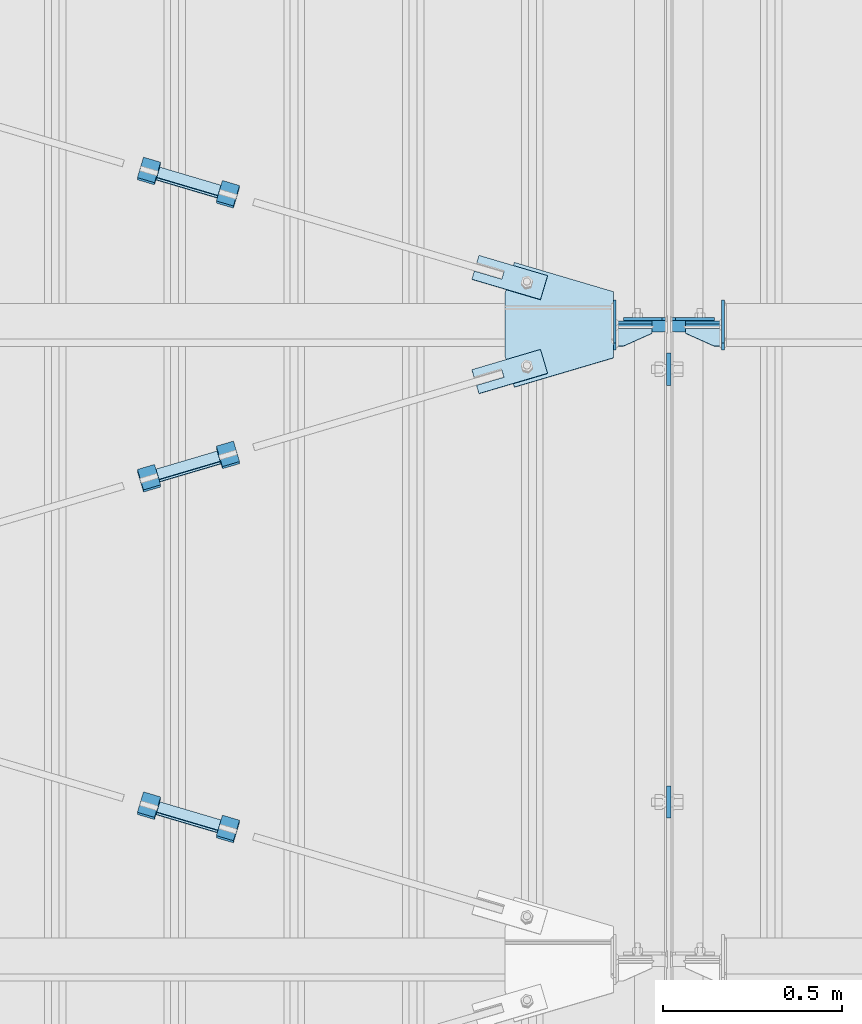
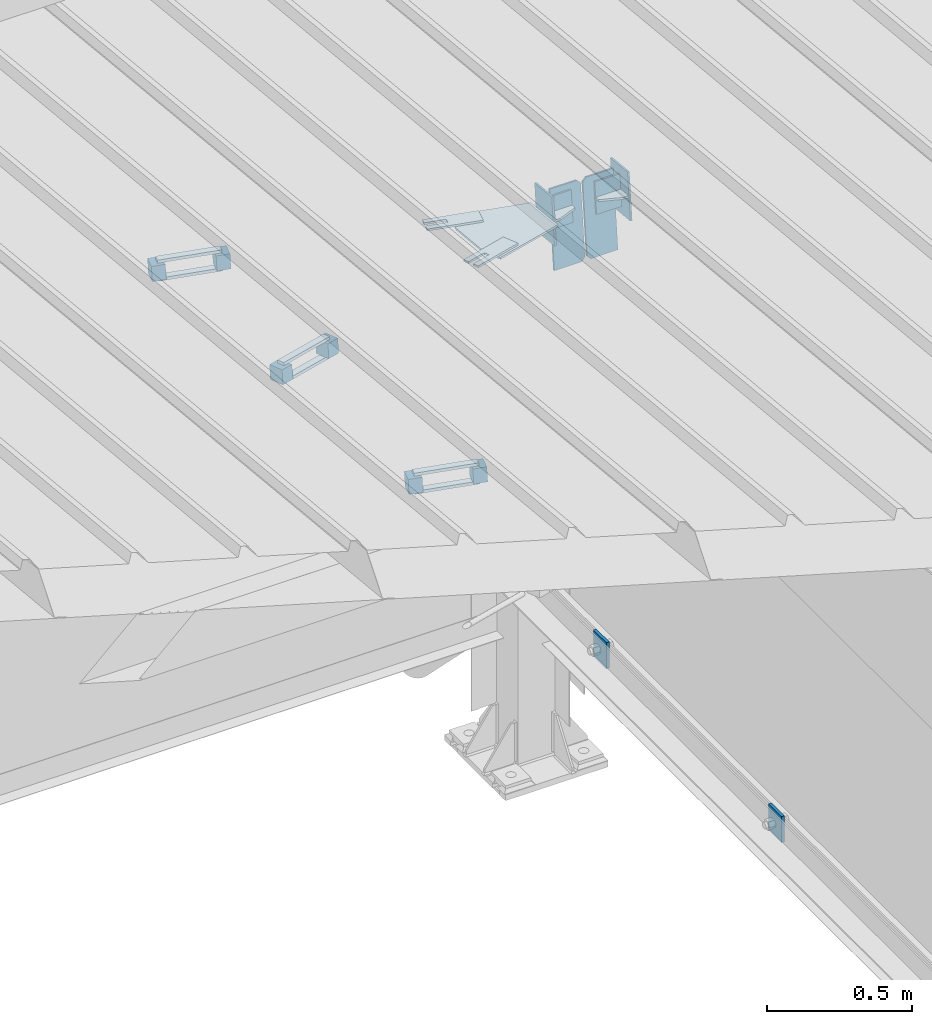
# One storey, part 154 of 709: 25 plates, 2 openings, 10 elements without a shape of their own.
"""IFC4 building model written with IfcOpenShell, lengths in millimetres."""

from ifc_helpers import new_model, si_unit, direction, frame, origin_with_axes, place, context, subcontext, project, spatial, line, indexed_curve, outline, extrude, material, element, aggregate, save


model = new_model("IFC4")

# Units and contexts
model_context = context("Model", 3, precision=0.2, world=origin_with_axes(), true_north=direction((0.0, 1.0)))
body_context = subcontext(model_context, "Body", "Model", "MODEL_VIEW")
ifc_project = project(units=[si_unit("LENGTHUNIT", "METRE", prefix="MILLI"), si_unit("AREAUNIT", "SQUARE_METRE"), si_unit("VOLUMEUNIT", "CUBIC_METRE"), si_unit("MASSUNIT", "GRAM", prefix="KILO"), si_unit("TIMEUNIT", "SECOND"), si_unit("PLANEANGLEUNIT", "RADIAN"), si_unit("SOLIDANGLEUNIT", "STERADIAN"), si_unit("THERMODYNAMICTEMPERATUREUNIT", "DEGREE_CELSIUS"), si_unit("LUMINOUSINTENSITYUNIT", "LUMEN")], contexts=[model_context])

# Site, building, storey
site_placement = place(None, origin_with_axes())
site = spatial("IfcSite", under=ifc_project, at=site_placement, CompositionType="ELEMENT")
building_placement = place(site_placement, origin_with_axes())
building = spatial("IfcBuilding", under=site, at=building_placement, Name="Undefined", CompositionType="ELEMENT")
storey_placement = place(building_placement, origin_with_axes())
storey = spatial("IfcBuildingStorey", under=building, at=storey_placement, Name="Undefined", CompositionType="ELEMENT", Elevation=0.0)

# Assembly, plates
assembly_1_placement = place(storey_placement, frame((46000.0, 21654.0, 7089.70002), z_axis=(-1.0, 0.0, 0.0), x_axis=(0.0, -0.9950371902, 0.099503719)))
assembly_1 = element("IfcElementAssembly", 1, at=assembly_1_placement, inside=storey)
ifc_material_1 = material(Name="C355-6", Category="STEEL")
plate_1_placement = place(assembly_1_placement, frame((6951.15059, 163.0, 127.0), z_axis=(-1.0, 0.0, 0.0), x_axis=(0.0, 0.0, -1.0)))
plate_1 = element("IfcPlate", 2, at=plate_1_placement, material=ifc_material_1, ObjectType="585", context=body_context, shape_type="SolidModel", body=[
    extrude(outline(indexed_curve([(0.0, 0.0), (108.0, 0.0), (123.0, 15.0), (123.0, 311.0), (108.0, 326.0), (0.0, 326.0)], segments=[line(1, 2, 3, 4, 5, 6, 1)])), frame((0.0, 0.0, 4.0), z_axis=(0.0, 0.0, 1.0), x_axis=(1.0, 0.0, 0.0)), (0.0, 0.0, -1.0), 8.0),
])
plate_2_placement = place(assembly_1_placement, frame((6951.15059, 163.0, -127.0), z_axis=(1.0, 0.0, 0.0), x_axis=(0.0, 0.0, 1.0)))
plate_2 = element("IfcPlate", 3, at=plate_2_placement, material=ifc_material_1, ObjectType="585", context=body_context, shape_type="SolidModel", body=[
    extrude(outline(indexed_curve([(0.0, 0.0), (108.0, 0.0), (123.0, 15.0), (123.0, 311.0), (108.0, 326.0), (0.0, 326.0)], segments=[line(1, 2, 3, 4, 5, 6, 1)])), frame((0.0, 0.0, 4.0), z_axis=(0.0, 0.0, 1.0), x_axis=(1.0, 0.0, 0.0)), (0.0, 0.0, -1.0), 8.0),
])
aggregate(assembly_1, [plate_1, plate_2])

# Assembly, plate
assembly_2_placement = place(storey_placement, frame((46000.0, 13358.5, 6100.00002), z_axis=(-1.0, 0.0, 0.0), x_axis=(0.0, 1.0, 0.0)))
assembly_2 = element("IfcElementAssembly", 4, at=assembly_2_placement, inside=storey)
plate_3_placement = place(assembly_2_placement, origin_with_axes())
plate_3 = element("IfcPlate", 5, at=plate_3_placement, material=ifc_material_1, ObjectType="491", context=body_context, shape_type="SolidModel", body=[
    extrude(outline(indexed_curve([(0.0, 0.0), (90.0, 0.0), (90.0, 110.0), (0.0, 110.0)], segments=[line(1, 2, 3, 4, 1)])), frame((0.0, 0.0, 6.0), z_axis=(0.0, 0.0, 1.0), x_axis=(1.0, 0.0, 0.0)), (0.0, 0.0, -1.0), 12.0),
])
aggregate(assembly_2, [plate_3])

assembly_3_placement = place(storey_placement, frame((46000.0, 14567.75, 6100.00002), z_axis=(-1.0, 0.0, 0.0), x_axis=(0.0, 1.0, 0.0)))
assembly_3 = element("IfcElementAssembly", 6, at=assembly_3_placement, inside=storey)
plate_4_placement = place(assembly_3_placement, origin_with_axes())
plate_4 = element("IfcPlate", 7, at=plate_4_placement, material=ifc_material_1, ObjectType="491", context=body_context, shape_type="SolidModel", body=[
    extrude(outline(indexed_curve([(0.0, 0.0), (90.0, 0.0), (90.0, 110.0), (0.0, 110.0)], segments=[line(1, 2, 3, 4, 1)])), frame((0.0, 0.0, 6.0), z_axis=(0.0, 0.0, 1.0), x_axis=(1.0, 0.0, 0.0)), (0.0, 0.0, -1.0), 12.0),
])
aggregate(assembly_3, [plate_4])

# Assembly, plate, voiding feature
assembly_4_placement = place(storey_placement, frame((44657.949, 14340.80292, 7902.42372), z_axis=(0.2847296511, -0.9538504697, 0.095385047), x_axis=(0.9586078582, 0.2833165921, -0.028331659)))
assembly_4 = element("IfcElementAssembly", 8, at=assembly_4_placement, inside=storey)
plate_5_placement = place(assembly_4_placement, frame((1036.31721, 0.0, 35.0), z_axis=(0.0, 1.0, 0.0), x_axis=(0.0, 0.0, -1.0)))
plate_5 = element("IfcPlate", 9, at=plate_5_placement, material=ifc_material_1, ObjectType="574", context=body_context, shape_type="SolidModel", body=[
    extrude(outline(indexed_curve([(0.0, 0.0), (70.0, 0.0), (70.0, 200.0), (0.0, 200.0)], segments=[line(1, 2, 3, 4, 1)])), frame((0.0, 0.0, 4.0), z_axis=(0.0, 0.0, 1.0), x_axis=(1.0, 0.0, 0.0)), (0.0, 0.0, -1.0), 8.0),
])
voiding_feature_1_placement = place(plate_5_placement, frame((24.0, 120.0, 0.0), z_axis=(0.0, 0.0, 1.0), x_axis=(1.0, 0.0, 0.0)))
element("IfcVoidingFeature", 10, at=voiding_feature_1_placement, cuts=plate_5, Name="PLATE", PredefinedType="HOLE", context=body_context, shape_type="SolidModel", body=[
    extrude(outline(indexed_curve([(0.0, 0.0), (22.0, 0.0), (22.0, 85.0), (0.0, 85.0)], segments=[line(1, 2, 3, 4, 1)])), frame((0.0, 0.0, 6.5), z_axis=(0.0, 0.0, 1.0), x_axis=(1.0, 0.0, 0.0)), (0.0, 0.0, -1.0), 13.0),
])
aggregate(assembly_4, [plate_5])

# Assembly, plates
assembly_5_placement = place(storey_placement, frame((44776.73079, 14347.75393, 7931.87825), z_axis=(-0.9586078582, -0.2833165918, 0.0283316592), x_axis=(-0.2847296509, 0.9538504698, -0.095385047)))
assembly_5 = element("IfcElementAssembly", 11, at=assembly_5_placement, inside=storey)
ifc_material_2 = material(Name="Steel_Undefined", Category="STEEL")
plate_6_placement = place(assembly_5_placement, frame((15.0, 66.0, 230.0), z_axis=(0.0, 1.0, 0.0), x_axis=(1.0, 0.0, 0.0)))
plate_6 = element("IfcPlate", 12, at=plate_6_placement, material=ifc_material_2, ObjectType="484", context=body_context, shape_type="SolidModel", body=[
    extrude(outline(indexed_curve([(0.0, 0.0), (30.0, 0.0), (30.0, 230.0), (0.0, 230.0)], segments=[line(1, 2, 3, 4, 1)])), frame((0.0, 0.0, 6.0), z_axis=(0.0, 0.0, 1.0), x_axis=(1.0, 0.0, 0.0)), (0.0, 0.0, -1.0), 12.0),
])
plate_7_placement = place(assembly_5_placement, origin_with_axes())
plate_7 = element("IfcPlate", 13, at=plate_7_placement, material=ifc_material_2, ObjectType="482", context=body_context, shape_type="SolidModel", body=[
    extrude(outline(indexed_curve([(0.0, 0.0), (60.0, 0.0), (60.0, 60.0), (0.0, 60.0)], segments=[line(1, 2, 3, 4, 1)])), frame((0.0, 0.0, 25.0), z_axis=(0.0, 0.0, 1.0), x_axis=(1.0, 0.0, 0.0)), (0.0, 0.0, -1.0), 50.0),
])
plate_8_placement = place(assembly_5_placement, frame((0.0, 0.0, 230.0), z_axis=(0.0, 0.0, 1.0), x_axis=(1.0, 0.0, 0.0)))
plate_8 = element("IfcPlate", 14, at=plate_8_placement, material=ifc_material_2, ObjectType="483", context=body_context, shape_type="SolidModel", body=[
    extrude(outline(indexed_curve([(0.0, 0.0), (60.0, 0.0), (60.0, 60.0), (0.0, 60.0)], segments=[line(1, 2, 3, 4, 1)])), frame((0.0, 0.0, 25.0), z_axis=(0.0, 0.0, 1.0), x_axis=(1.0, 0.0, 0.0)), (0.0, 0.0, -1.0), 50.0),
])
plate_9_placement = place(assembly_5_placement, frame((15.0, -6.0, 230.0), z_axis=(0.0, 1.0, 0.0), x_axis=(1.0, 0.0, 0.0)))
plate_9 = element("IfcPlate", 15, at=plate_9_placement, material=ifc_material_2, ObjectType="484", context=body_context, shape_type="SolidModel", body=[
    extrude(outline(indexed_curve([(0.0, 0.0), (30.0, 0.0), (30.0, 230.0), (0.0, 230.0)], segments=[line(1, 2, 3, 4, 1)])), frame((0.0, 0.0, 6.0), z_axis=(0.0, 0.0, 1.0), x_axis=(1.0, 0.0, 0.0)), (0.0, 0.0, -1.0), 12.0),
])
aggregate(assembly_5, [plate_6, plate_7, plate_8, plate_9])

assembly_6_placement = place(storey_placement, frame((44759.64701, 13302.57732, 8036.39591), z_axis=(-0.9586078582, 0.2833165918, -0.0283316592), x_axis=(0.2847296509, 0.9538504698, -0.095385047)))
assembly_6 = element("IfcElementAssembly", 16, at=assembly_6_placement, inside=storey)
plate_10_placement = place(assembly_6_placement, frame((0.0, 0.0, 230.0), z_axis=(0.0, 0.0, 1.0), x_axis=(1.0, 0.0, 0.0)))
plate_10 = element("IfcPlate", 17, at=plate_10_placement, material=ifc_material_2, ObjectType="483", context=body_context, shape_type="SolidModel", body=[
    extrude(outline(indexed_curve([(0.0, 0.0), (60.0, 0.0), (60.0, 60.0), (0.0, 60.0)], segments=[line(1, 2, 3, 4, 1)])), frame((0.0, 0.0, 25.0), z_axis=(0.0, 0.0, 1.0), x_axis=(1.0, 0.0, 0.0)), (0.0, 0.0, -1.0), 50.0),
])
plate_11_placement = place(assembly_6_placement, frame((15.0, -6.0, 230.0), z_axis=(0.0, 1.0, 0.0), x_axis=(1.0, 0.0, 0.0)))
plate_11 = element("IfcPlate", 18, at=plate_11_placement, material=ifc_material_2, ObjectType="484", context=body_context, shape_type="SolidModel", body=[
    extrude(outline(indexed_curve([(0.0, 0.0), (30.0, 0.0), (30.0, 230.0), (0.0, 230.0)], segments=[line(1, 2, 3, 4, 1)])), frame((0.0, 0.0, 6.0), z_axis=(0.0, 0.0, 1.0), x_axis=(1.0, 0.0, 0.0)), (0.0, 0.0, -1.0), 12.0),
])
plate_12_placement = place(assembly_6_placement, origin_with_axes())
plate_12 = element("IfcPlate", 19, at=plate_12_placement, material=ifc_material_2, ObjectType="482", context=body_context, shape_type="SolidModel", body=[
    extrude(outline(indexed_curve([(0.0, 0.0), (60.0, 0.0), (60.0, 60.0), (0.0, 60.0)], segments=[line(1, 2, 3, 4, 1)])), frame((0.0, 0.0, 25.0), z_axis=(0.0, 0.0, 1.0), x_axis=(1.0, 0.0, 0.0)), (0.0, 0.0, -1.0), 50.0),
])
plate_13_placement = place(assembly_6_placement, frame((15.0, 66.0, 230.0), z_axis=(0.0, 1.0, 0.0), x_axis=(1.0, 0.0, 0.0)))
plate_13 = element("IfcPlate", 20, at=plate_13_placement, material=ifc_material_2, ObjectType="484", context=body_context, shape_type="SolidModel", body=[
    extrude(outline(indexed_curve([(0.0, 0.0), (30.0, 0.0), (30.0, 230.0), (0.0, 230.0)], segments=[line(1, 2, 3, 4, 1)])), frame((0.0, 0.0, 6.0), z_axis=(0.0, 0.0, 1.0), x_axis=(1.0, 0.0, 0.0)), (0.0, 0.0, -1.0), 12.0),
])
aggregate(assembly_6, [plate_10, plate_11, plate_12, plate_13])

# Assembly, plate, voiding feature
assembly_7_placement = place(storey_placement, frame((44657.949, 15134.08938, 7823.09508), z_axis=(-0.2847296511, -0.9538504697, 0.095385047), x_axis=(0.9586078582, -0.2833165921, 0.028331659)))
assembly_7 = element("IfcElementAssembly", 21, at=assembly_7_placement, inside=storey)
plate_14_placement = place(assembly_7_placement, frame((1036.31721, 0.0, 35.0), z_axis=(0.0, 1.0, 0.0), x_axis=(0.0, 0.0, -1.0)))
plate_14 = element("IfcPlate", 22, at=plate_14_placement, material=ifc_material_1, ObjectType="574", context=body_context, shape_type="SolidModel", body=[
    extrude(outline(indexed_curve([(0.0, 0.0), (70.0, 0.0), (70.0, 200.0), (0.0, 200.0)], segments=[line(1, 2, 3, 4, 1)])), frame((0.0, 0.0, 4.0), z_axis=(0.0, 0.0, 1.0), x_axis=(1.0, 0.0, 0.0)), (0.0, 0.0, -1.0), 8.0),
])
voiding_feature_2_placement = place(plate_14_placement, frame((24.0, 120.0, 0.0), z_axis=(0.0, 0.0, 1.0), x_axis=(1.0, 0.0, 0.0)))
element("IfcVoidingFeature", 23, at=voiding_feature_2_placement, cuts=plate_14, Name="PLATE", PredefinedType="HOLE", context=body_context, shape_type="SolidModel", body=[
    extrude(outline(indexed_curve([(0.0, 0.0), (22.0, 0.0), (22.0, 85.0), (0.0, 85.0)], segments=[line(1, 2, 3, 4, 1)])), frame((0.0, 0.0, 6.5), z_axis=(0.0, 0.0, 1.0), x_axis=(1.0, 0.0, 0.0)), (0.0, 0.0, -1.0), 13.0),
])
aggregate(assembly_7, [plate_14])

# Assembly, plates
assembly_8_placement = place(storey_placement, frame((44759.64701, 15075.87757, 7859.06589), z_axis=(-0.9586078582, 0.2833165918, -0.0283316592), x_axis=(0.2847296509, 0.9538504698, -0.095385047)))
assembly_8 = element("IfcElementAssembly", 24, at=assembly_8_placement, inside=storey)
plate_15_placement = place(assembly_8_placement, origin_with_axes())
plate_15 = element("IfcPlate", 25, at=plate_15_placement, material=ifc_material_2, ObjectType="482", context=body_context, shape_type="SolidModel", body=[
    extrude(outline(indexed_curve([(0.0, 0.0), (60.0, 0.0), (60.0, 60.0), (0.0, 60.0)], segments=[line(1, 2, 3, 4, 1)])), frame((0.0, 0.0, 25.0), z_axis=(0.0, 0.0, 1.0), x_axis=(1.0, 0.0, 0.0)), (0.0, 0.0, -1.0), 50.0),
])
plate_16_placement = place(assembly_8_placement, frame((15.0, 66.0, 230.0), z_axis=(0.0, 1.0, 0.0), x_axis=(1.0, 0.0, 0.0)))
plate_16 = element("IfcPlate", 26, at=plate_16_placement, material=ifc_material_2, ObjectType="484", context=body_context, shape_type="SolidModel", body=[
    extrude(outline(indexed_curve([(0.0, 0.0), (30.0, 0.0), (30.0, 230.0), (0.0, 230.0)], segments=[line(1, 2, 3, 4, 1)])), frame((0.0, 0.0, 6.0), z_axis=(0.0, 0.0, 1.0), x_axis=(1.0, 0.0, 0.0)), (0.0, 0.0, -1.0), 12.0),
])
plate_17_placement = place(assembly_8_placement, frame((15.0, -6.0, 230.0), z_axis=(0.0, 1.0, 0.0), x_axis=(1.0, 0.0, 0.0)))
plate_17 = element("IfcPlate", 27, at=plate_17_placement, material=ifc_material_2, ObjectType="484", context=body_context, shape_type="SolidModel", body=[
    extrude(outline(indexed_curve([(0.0, 0.0), (30.0, 0.0), (30.0, 230.0), (0.0, 230.0)], segments=[line(1, 2, 3, 4, 1)])), frame((0.0, 0.0, 6.0), z_axis=(0.0, 0.0, 1.0), x_axis=(1.0, 0.0, 0.0)), (0.0, 0.0, -1.0), 12.0),
])
plate_18_placement = place(assembly_8_placement, frame((0.0, 0.0, 230.0), z_axis=(0.0, 0.0, 1.0), x_axis=(1.0, 0.0, 0.0)))
plate_18 = element("IfcPlate", 28, at=plate_18_placement, material=ifc_material_2, ObjectType="483", context=body_context, shape_type="SolidModel", body=[
    extrude(outline(indexed_curve([(0.0, 0.0), (60.0, 0.0), (60.0, 60.0), (0.0, 60.0)], segments=[line(1, 2, 3, 4, 1)])), frame((0.0, 0.0, 25.0), z_axis=(0.0, 0.0, 1.0), x_axis=(1.0, 0.0, 0.0)), (0.0, 0.0, -1.0), 50.0),
])
aggregate(assembly_8, [plate_15, plate_16, plate_17, plate_18])

assembly_9_placement = place(storey_placement, frame((46000.0, 14736.65012, 7854.7991), z_axis=(0.0, -0.9950371902, 0.099503719), x_axis=(-1.0, 0.0, 0.0)))
assembly_9 = element("IfcElementAssembly", 29, at=assembly_9_placement, inside=storey)
plate_19_placement = place(assembly_9_placement, frame((47.0, -65.0, 0.0), z_axis=(0.0, 0.0, 1.0), x_axis=(1.0, 0.0, 0.0)))
plate_19 = element("IfcPlate", 30, at=plate_19_placement, material=ifc_material_1, ObjectType="587", context=body_context, shape_type="SolidModel", body=[
    extrude(outline(indexed_curve([(0.0, 0.0), (100.0, 0.0), (100.0, 130.0), (0.0, 130.0)], segments=[line(1, 2, 3, 4, 1)])), frame((0.0, 0.0, 4.0), z_axis=(0.0, 0.0, 1.0), x_axis=(1.0, 0.0, 0.0)), (0.0, 0.0, -1.0), 8.0),
])
plate_20_placement = place(assembly_9_placement, frame((151.0, -98.0, -60.0), z_axis=(-1.0, 0.0, 0.0), x_axis=(0.0, 0.0, 1.0)))
plate_20 = element("IfcPlate", 31, at=plate_20_placement, material=ifc_material_1, ObjectType="586", context=body_context, shape_type="SolidModel", body=[
    extrude(outline(indexed_curve([(0.0, 0.0), (120.0, 0.0), (120.0, 196.0), (0.0, 196.0)], segments=[line(1, 2, 3, 4, 1)])), frame((0.0, 0.0, 4.0), z_axis=(0.0, 0.0, 1.0), x_axis=(1.0, 0.0, 0.0)), (0.0, 0.0, -1.0), 8.0),
])
plate_21_placement = place(assembly_9_placement, frame((47.0, 0.0, 60.0), z_axis=(0.0, 1.0, 0.0), x_axis=(1.0, 0.0, 0.0)))
plate_21 = element("IfcPlate", 32, at=plate_21_placement, material=ifc_material_1, ObjectType="588", context=body_context, shape_type="SolidModel", body=[
    extrude(outline(indexed_curve([(0.0, 36.0), (80.0, 0.0), (100.0, 0.0), (100.0, 56.0), (0.0, 56.0)], segments=[line(1, 2, 3, 4, 5, 1)])), frame((0.0, 0.0, 4.0), z_axis=(0.0, 0.0, 1.0), x_axis=(1.0, 0.0, 0.0)), (0.0, 0.0, -1.0), 8.0),
])
plate_22_placement = place(assembly_9_placement, frame((154.99945, 0.0, 92.98165), z_axis=(0.0, -1.0, 0.0), x_axis=(0.0, 0.0, -1.0)))
plate_22 = element("IfcPlate", 33, at=plate_22_placement, material=ifc_material_1, ObjectType="576", context=body_context, shape_type="SolidModel", body=[
    extrude(outline(indexed_curve([(0.0, 0.0), (185.9633, 0.0), (268.14324, 276.67769), (181.86854, 302.30336), (4.09476, 302.30336), (-82.17995, 276.67769)], segments=[line(1, 2, 3, 4, 5, 6, 1)])), frame((0.0, 0.0, 4.0), z_axis=(0.0, 0.0, 1.0), x_axis=(1.0, 0.0, 0.0)), (0.0, 0.0, -1.0), 8.0),
])
aggregate(assembly_9, [plate_19, plate_20, plate_21, plate_22])

assembly_10_placement = place(storey_placement, frame((50000.0, 14736.65012, 7854.7991), z_axis=(0.0, -0.9950371902, 0.099503719), x_axis=(-1.0, 0.0, 0.0)))
assembly_10 = element("IfcElementAssembly", 34, at=assembly_10_placement, inside=storey)
plate_23_placement = place(assembly_10_placement, frame((3953.0, 65.0, 0.0), z_axis=(0.0, 0.0, 1.0), x_axis=(-1.0, 0.0, 0.0)))
plate_23 = element("IfcPlate", 35, at=plate_23_placement, material=ifc_material_1, ObjectType="587", context=body_context, shape_type="SolidModel", body=[
    extrude(outline(indexed_curve([(0.0, 0.0), (100.0, 0.0), (100.0, 130.0), (0.0, 130.0)], segments=[line(1, 2, 3, 4, 1)])), frame((0.0, 0.0, 4.0), z_axis=(0.0, 0.0, 1.0), x_axis=(1.0, 0.0, 0.0)), (0.0, 0.0, -1.0), 8.0),
])
plate_24_placement = place(assembly_10_placement, frame((3953.0, 0.0, 60.0), z_axis=(0.0, -1.0, 0.0), x_axis=(-1.0, 0.0, 0.0)))
plate_24 = element("IfcPlate", 36, at=plate_24_placement, material=ifc_material_1, ObjectType="588", context=body_context, shape_type="SolidModel", body=[
    extrude(outline(indexed_curve([(0.0, 36.0), (80.0, 0.0), (100.0, 0.0), (100.0, 56.0), (0.0, 56.0)], segments=[line(1, 2, 3, 4, 5, 1)])), frame((0.0, 0.0, 4.0), z_axis=(0.0, 0.0, 1.0), x_axis=(1.0, 0.0, 0.0)), (0.0, 0.0, -1.0), 8.0),
])
plate_25_placement = place(assembly_10_placement, frame((3849.0, -98.0, 60.0), z_axis=(1.0, 0.0, 0.0), x_axis=(0.0, 0.0, -1.0)))
plate_25 = element("IfcPlate", 37, at=plate_25_placement, material=ifc_material_1, ObjectType="586", context=body_context, shape_type="SolidModel", body=[
    extrude(outline(indexed_curve([(0.0, 0.0), (120.0, 0.0), (120.0, 196.0), (0.0, 196.0)], segments=[line(1, 2, 3, 4, 1)])), frame((0.0, 0.0, 4.0), z_axis=(0.0, 0.0, 1.0), x_axis=(1.0, 0.0, 0.0)), (0.0, 0.0, -1.0), 8.0),
])
aggregate(assembly_10, [plate_23, plate_24, plate_25])

save(model, "model.ifc")
